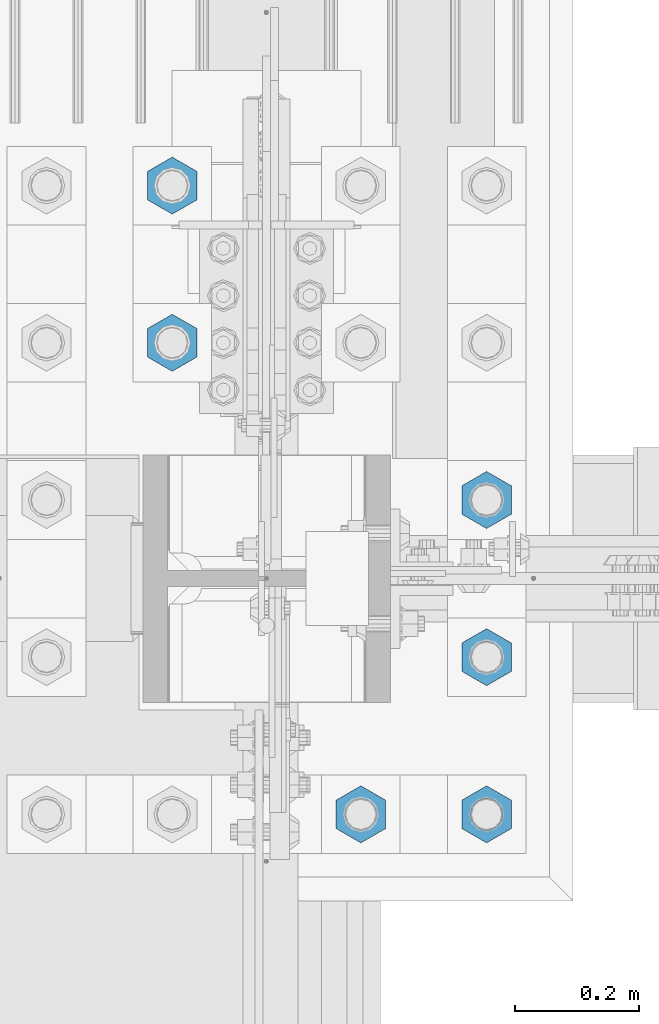
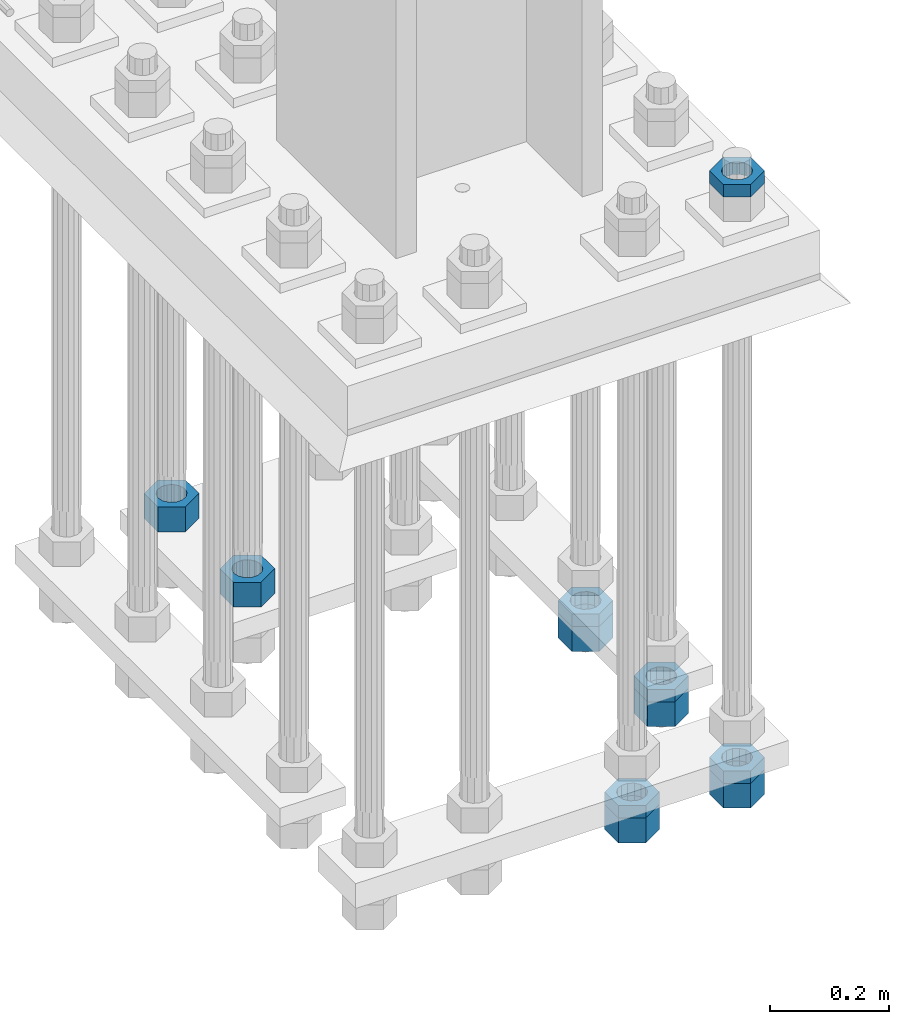
# One storey, part 2196 of 3843: 11 beams, 1 element without a shape of its own.
"""IFC2X3 building model written with IfcOpenShell, lengths in millimetres."""

import ifcopenshell
import ifcopenshell.guid

model = None  # the IFC model being written
_history = None  # IfcOwnerHistory: only IFC2X3 demands one
_inside = {}  # id of a spatial element -> (the spatial element, [elements in it])
_under = {}  # id of a project, library or spatial element -> (it, [spatial elements below it])
_declared = {}  # id of a project -> (the project, [libraries it declares])
_typed = {}  # id of a type object -> (the type object, [elements of that type])
_made_of = {}  # id of a material, layer set ... -> (it, [elements and type objects made of it])


def new_model(schema):
    """Start an empty IFC model of exactly this schema.

    Asked for "IFC4X3", IfcOpenShell would pick the latest addendum, in which some entities
    have other attributes; the version numbers below select the first issue.
    IFC2X3 requires an IfcOwnerHistory on every rooted entity: one is made here for all.
    """
    global model, _history
    if schema == "IFC4X3":
        model = ifcopenshell.file(schema_version=(4, 3, 0, 0))
    else:
        model = ifcopenshell.file(schema=schema)
    _inside.clear()
    _under.clear()
    _declared.clear()
    _typed.clear()
    _made_of.clear()
    _history = None
    if model.schema == "IFC2X3":
        org = make("IfcOrganization", Name="unknown")
        user = make(
            "IfcPersonAndOrganization",
            ThePerson=make("IfcPerson", FamilyName="unknown"),
            TheOrganization=org,
        )
        app = make(
            "IfcApplication",
            ApplicationDeveloper=org,
            Version="unknown",
            ApplicationFullName="unknown",
            ApplicationIdentifier="unknown",
        )
        _history = make(
            "IfcOwnerHistory",
            OwningUser=user,
            OwningApplication=app,
            ChangeAction="ADDED",
            CreationDate=0,
        )
    return model


def make(cls, **values):
    """One entity of the class cls with the attributes given. An attribute that is None is left unset."""
    return model.create_entity(
        cls, **{name: value for name, value in values.items() if value is not None}
    )


def rooted(cls, **values):
    """An entity with a GlobalId (a new one), such as an element, a storey or a relation."""
    return make(cls, GlobalId=ifcopenshell.guid.new(), OwnerHistory=_history, **values)


def si_unit(unit_type, name, prefix=None):
    """IfcSIUnit, for example si_unit("LENGTHUNIT", "METRE", prefix="MILLI")."""
    return make("IfcSIUnit", UnitType=unit_type, Prefix=prefix, Name=name)


def assignment(units):
    """IfcUnitAssignment: the units of a project."""
    return None if units is None else make("IfcUnitAssignment", Units=units)


def point(xyz):
    """IfcCartesianPoint."""
    return None if xyz is None else make("IfcCartesianPoint", Coordinates=xyz)


def direction(xyz):
    """IfcDirection."""
    return None if xyz is None else make("IfcDirection", DirectionRatios=xyz)


def frame(location, z_axis=None, x_axis=None):
    """IfcAxis2Placement3D, a coordinate frame: its origin and axes. An axis left out is left unset."""
    return make(
        "IfcAxis2Placement3D",
        Location=point(location),
        Axis=direction(z_axis),
        RefDirection=direction(x_axis),
    )


def origin_with_axes():
    """The frame at (0, 0, 0) with the z axis (0, 0, 1) and the x axis (1, 0, 0) written out."""
    return frame((0.0, 0.0, 0.0), z_axis=(0.0, 0.0, 1.0), x_axis=(1.0, 0.0, 0.0))


def place(relative_to, where):
    """IfcLocalPlacement: puts the frame where relative to a parent placement (None: the world)."""
    return make(
        "IfcLocalPlacement", PlacementRelTo=relative_to, RelativePlacement=where
    )


def context(
    kind, dimensions, precision=None, world=None, true_north=None, identifier=None
):
    """IfcGeometricRepresentationContext, for example the 3D "Model" context."""
    return make(
        "IfcGeometricRepresentationContext",
        ContextIdentifier=identifier,
        ContextType=kind,
        CoordinateSpaceDimension=dimensions,
        Precision=precision,
        WorldCoordinateSystem=world,
        TrueNorth=true_north,
    )


def subcontext(parent, identifier, kind, view, scale=None):
    """IfcGeometricRepresentationSubContext, for example "Body" below "Model"."""
    return make(
        "IfcGeometricRepresentationSubContext",
        ContextIdentifier=identifier,
        ContextType=kind,
        ParentContext=parent,
        TargetScale=scale,
        TargetView=view,
    )


def project(units=None, contexts=None):
    """IfcProject with its units and contexts."""
    return rooted(
        "IfcProject",
        Name="project",
        RepresentationContexts=contexts,
        UnitsInContext=assignment(units),
    )


def spatial(cls, under=None, at=None, **own):
    """A site, building, storey or space (cls), placed at a placement, below another one or the project."""
    s = rooted(cls, ObjectPlacement=at, **own)
    if under is not None:
        _under.setdefault(under.id(), (under, []))[1].append(s)
    return s


def faces_of(points, faces, orient=None, outer=None):
    """IfcFace entities. A face is a list of loops; a loop is a list of indices into points, from 0.

    orient and outer hold one flag for each loop. By default every Orientation is true, the
    first loop of a face is its IfcFaceOuterBound and the others are IfcFaceBound.
    """
    made = []
    for i, loops in enumerate(faces):
        bounds = []
        for j, loop in enumerate(loops):
            is_outer = j == 0 if outer is None else outer[i][j]
            bounds.append(
                make(
                    "IfcFaceOuterBound" if is_outer else "IfcFaceBound",
                    Bound=make("IfcPolyLoop", Polygon=[points[k] for k in loop]),
                    Orientation=True if orient is None else orient[i][j],
                )
            )
        made.append(make("IfcFace", Bounds=bounds))
    return made


def faceted_brep(points, faces, orient=None, outer=None, voids=None):
    """IfcFacetedBrep: a solid bounded by flat faces; with voids (closed shells), ...WithVoids."""
    shared = [point(p) for p in points]
    hull = make("IfcClosedShell", CfsFaces=faces_of(shared, faces, orient, outer))
    if voids is None:
        return make("IfcFacetedBrep", Outer=hull)
    return make(
        "IfcFacetedBrepWithVoids",
        Outer=hull,
        Voids=[
            make(cls, CfsFaces=faces_of(shared, fs, o, b)) for cls, fs, o, b in voids
        ],
    )


def shape(context_of_items, identifier, shape_type, items):
    """IfcShapeRepresentation: the items that make up one representation, for example the "Body"."""
    return make(
        "IfcShapeRepresentation",
        ContextOfItems=context_of_items,
        RepresentationIdentifier=identifier,
        RepresentationType=shape_type,
        Items=items,
    )


def material(Name=None, Category=None):
    """IfcMaterial."""
    return make("IfcMaterial", Name=Name, Category=Category)


def made_of(thing, what):
    """Note that an element or type object is made of a material, layer set ...; save() writes the relation."""
    if what is not None:
        _made_of.setdefault(what.id(), (what, []))[1].append(thing)
    return thing


def type_object(cls, material=None, **own):
    """A type object (cls), such as IfcWallType, which elements share."""
    return made_of(rooted(cls, **own), material)


def element(
    cls,
    number,
    at=None,
    inside=None,
    cuts=None,
    type_object=None,
    material=None,
    context=None,
    identifier="Body",
    shape_type=None,
    held_by="IfcProductDefinitionShape",
    body=None,
    shapes=None,
    **own,
):
    """One element of the class cls, such as IfcWall. Its Tag is "e" and its number.

    at: its placement. inside: the storey or other place that contains it. cuts: it is an
    opening in that element (IfcRelVoidsElement). A single representation is given by context,
    identifier, shape_type and body (its items); several are given by shapes. held_by: the class
    of the entity that holds the representations. save() writes the other relations.
    """
    e = rooted(cls, Tag="e%d" % number, ObjectPlacement=at, **own)
    if body is not None:
        shapes = [shape(context, identifier, shape_type, body)]
    if shapes is not None:
        e.Representation = make(held_by, Representations=shapes)
    if inside is not None:
        _inside.setdefault(inside.id(), (inside, []))[1].append(e)
    if cuts is not None:
        rooted(
            "IfcRelVoidsElement", RelatingBuildingElement=cuts, RelatedOpeningElement=e
        )
    if type_object is not None:
        _typed.setdefault(type_object.id(), (type_object, []))[1].append(e)
    return made_of(e, material)


def aggregate(whole, parts):
    """IfcRelAggregates: a whole, such as a stair, and the parts it consists of."""
    return rooted("IfcRelAggregates", RelatingObject=whole, RelatedObjects=parts)


def save(model, path):
    """Write the relations noted so far, then the file.

    IfcRelAggregates (storeys below a building ...), IfcRelContainedInSpatialStructure (elements
    in a storey), IfcRelDefinesByType, IfcRelAssociatesMaterial and IfcRelDeclares: one each for
    every whole, place, type object, material and project.
    """
    for whole, parts in _under.values():
        aggregate(whole, parts)
    for where, things in _inside.values():
        rooted(
            "IfcRelContainedInSpatialStructure",
            RelatedElements=things,
            RelatingStructure=where,
        )
    for kind, things in _typed.values():
        rooted("IfcRelDefinesByType", RelatedObjects=things, RelatingType=kind)
    for what, things in _made_of.values():
        rooted("IfcRelAssociatesMaterial", RelatedObjects=things, RelatingMaterial=what)
    for by, libraries in _declared.values():
        rooted("IfcRelDeclares", RelatingContext=by, RelatedDefinitions=libraries)
    model.write(path)


model = new_model("IFC2X3")

# Units and contexts
model_context = context("Model", 3, precision=1e-05, world=origin_with_axes())
body_context = subcontext(model_context, "Body", "Model", "MODEL_VIEW")
ifc_project = project(units=[si_unit("LENGTHUNIT", "METRE", prefix="MILLI"), si_unit("AREAUNIT", "SQUARE_METRE"), si_unit("VOLUMEUNIT", "CUBIC_METRE"), si_unit("MASSUNIT", "GRAM", prefix="KILO"), si_unit("TIMEUNIT", "SECOND"), si_unit("PLANEANGLEUNIT", "RADIAN"), si_unit("SOLIDANGLEUNIT", "STERADIAN"), si_unit("THERMODYNAMICTEMPERATUREUNIT", "DEGREE_CELSIUS"), si_unit("LUMINOUSINTENSITYUNIT", "LUMEN")], contexts=[model_context])

# Site, building, storey
site_placement = place(None, origin_with_axes())
site = spatial("IfcSite", under=ifc_project, at=site_placement, CompositionType="ELEMENT")
building_placement = place(site_placement, origin_with_axes())
building = spatial("IfcBuilding", under=site, at=building_placement, Name="Undefined", CompositionType="ELEMENT")
storey_placement = place(building_placement, origin_with_axes())
storey = spatial("IfcBuildingStorey", under=building, at=storey_placement, Name="Undefined", CompositionType="ELEMENT", Elevation=0.0)

# Assembly, beams
assembly_placement = place(storey_placement, origin_with_axes())
assembly = element("IfcElementAssembly", 1, at=assembly_placement, inside=storey, Name="TEMPLATE", AssemblyPlace="NOTDEFINED", PredefinedType="RIGID_FRAME")
ifc_material = material(Name="STEEL/A572-50")
beam_type_1 = type_object("IfcBeamType", Name="2_HALF_NUT", PredefinedType="NOTDEFINED")
beam_1_placement = place(assembly_placement, frame((36931.6, 50177.7, 30257.75), z_axis=(1.0, 0.0, 0.0), x_axis=(0.0, 0.0, -1.0)))
beam_1 = element("IfcBeam", 2, at=beam_1_placement, type_object=beam_type_1, material=ifc_material, Name="NUT", ObjectType="2_HALF_NUT", context=body_context, shape_type="Brep", body=[
    faceted_brep([(0.0, -46.0369987487793, 0.0), (0.0, -23.0184993743896, -39.869213104248), (25.4000000000015, -23.0184993743896, -39.869213104248), (25.4000000000015, -46.0369987487793, 0.0), (0.0, 23.0184993743896, -39.869213104248), (25.4000000000015, 23.0184993743896, -39.869213104248), (0.0, 46.0369987487793, 0.0), (25.4000000000015, 46.0369987487793, 0.0), (0.0, 23.0184993743896, 39.869213104248), (25.4000000000015, 23.0184993743896, 39.869213104248), (0.0, -23.0184993743896, 39.869213104248), (25.4000000000015, -23.0184993743896, 39.869213104248), (0.0, 0.0, 26.1940002441406), (0.0, 11.3650617044477, 23.5999013092805), (25.4000000000015, 11.3650617044477, 23.5999013092805), (25.4000000000015, 0.0, 26.1940002441406), (0.0, 20.4791109456419, 16.3316083006721), (25.4000000000015, 20.4791109456419, 16.3316083006721), (0.0, 25.5370200498292, 5.82867859874386), (25.4000000000015, 25.5370200498292, 5.82867859874386), (0.0, 25.5370200498292, -5.82867859874386), (25.4000000000015, 25.5370200498292, -5.82867859874386), (0.0, 20.4791109456419, -16.3316083006721), (25.4000000000015, 20.4791109456419, -16.3316083006721), (0.0, 11.3650617044477, -23.5999013092805), (25.4000000000015, 11.3650617044477, -23.5999013092805), (0.0, 0.0, -26.1940002441406), (25.4000000000015, 0.0, -26.1940002441406), (0.0, -11.3650617044477, -23.5999013092805), (25.4000000000015, -11.3650617044477, -23.5999013092805), (0.0, -20.4791109456419, -16.3316083006721), (25.4000000000015, -20.4791109456419, -16.3316083006721), (0.0, -25.5370200498292, -5.82867859874386), (25.4000000000015, -25.5370200498292, -5.82867859874386), (0.0, -25.5370200498292, 5.82867859874386), (25.4000000000015, -25.5370200498292, 5.82867859874386), (0.0, -20.4791109456419, 16.3316083006721), (25.4000000000015, -20.4791109456419, 16.3316083006721), (0.0, -11.3650617044477, 23.5999013092805), (25.4000000000015, -11.3650617044477, 23.5999013092805)], [[[0, 1, 2, 3]], [[1, 4, 5, 2]], [[4, 6, 7, 5]], [[6, 8, 9, 7]], [[8, 10, 11, 9]], [[10, 0, 3, 11]], [[12, 13, 14, 15]], [[13, 16, 17, 14]], [[16, 18, 19, 17]], [[18, 20, 21, 19]], [[20, 22, 23, 21]], [[22, 24, 25, 23]], [[24, 26, 27, 25]], [[26, 28, 29, 27]], [[28, 30, 31, 29]], [[30, 32, 33, 31]], [[32, 34, 35, 33]], [[34, 36, 37, 35]], [[36, 38, 39, 37]], [[38, 12, 15, 39]], [[5, 7, 9, 11, 3, 2], [17, 19, 21, 23, 25, 27, 29, 31, 33, 35, 37, 39, 15, 14]], [[10, 8, 6, 4, 1, 0], [38, 36, 34, 32, 30, 28, 26, 24, 22, 20, 18, 16, 13, 12]]]),
])
beam_2_placement = place(assembly_placement, frame((36931.6, 50177.7, 29057.6), z_axis=(1.0, 0.0, 0.0), x_axis=(0.0, 0.0, -1.0)))
beam_2 = element("IfcBeam", 3, at=beam_2_placement, type_object=beam_type_1, material=ifc_material, Name="NUT", ObjectType="2_HALF_NUT", context=body_context, shape_type="Brep", body=[
    faceted_brep([(0.0, -46.0369987487793, 0.0), (0.0, -23.0184993743896, -39.869213104248), (25.4000000000015, -23.0184993743896, -39.869213104248), (25.4000000000015, -46.0369987487793, 0.0), (0.0, 23.0184993743896, -39.869213104248), (25.4000000000015, 23.0184993743896, -39.869213104248), (0.0, 46.0369987487793, 0.0), (25.4000000000015, 46.0369987487793, 0.0), (0.0, 23.0184993743896, 39.869213104248), (25.4000000000015, 23.0184993743896, 39.869213104248), (0.0, -23.0184993743896, 39.869213104248), (25.4000000000015, -23.0184993743896, 39.869213104248), (0.0, 0.0, 26.1940002441406), (0.0, 11.3650617044477, 23.5999013092805), (25.4000000000015, 11.3650617044477, 23.5999013092805), (25.4000000000015, 0.0, 26.1940002441406), (0.0, 20.4791109456419, 16.3316083006721), (25.4000000000015, 20.4791109456419, 16.3316083006721), (0.0, 25.5370200498292, 5.82867859874386), (25.4000000000015, 25.5370200498292, 5.82867859874386), (0.0, 25.5370200498292, -5.82867859874386), (25.4000000000015, 25.5370200498292, -5.82867859874386), (0.0, 20.4791109456419, -16.3316083006721), (25.4000000000015, 20.4791109456419, -16.3316083006721), (0.0, 11.3650617044477, -23.5999013092805), (25.4000000000015, 11.3650617044477, -23.5999013092805), (0.0, 0.0, -26.1940002441406), (25.4000000000015, 0.0, -26.1940002441406), (0.0, -11.3650617044477, -23.5999013092805), (25.4000000000015, -11.3650617044477, -23.5999013092805), (0.0, -20.4791109456419, -16.3316083006721), (25.4000000000015, -20.4791109456419, -16.3316083006721), (0.0, -25.5370200498292, -5.82867859874386), (25.4000000000015, -25.5370200498292, -5.82867859874386), (0.0, -25.5370200498292, 5.82867859874386), (25.4000000000015, -25.5370200498292, 5.82867859874386), (0.0, -20.4791109456419, 16.3316083006721), (25.4000000000015, -20.4791109456419, 16.3316083006721), (0.0, -11.3650617044477, 23.5999013092805), (25.4000000000015, -11.3650617044477, 23.5999013092805)], [[[0, 1, 2, 3]], [[1, 4, 5, 2]], [[4, 6, 7, 5]], [[6, 8, 9, 7]], [[8, 10, 11, 9]], [[10, 0, 3, 11]], [[12, 13, 14, 15]], [[13, 16, 17, 14]], [[16, 18, 19, 17]], [[18, 20, 21, 19]], [[20, 22, 23, 21]], [[22, 24, 25, 23]], [[24, 26, 27, 25]], [[26, 28, 29, 27]], [[28, 30, 31, 29]], [[30, 32, 33, 31]], [[32, 34, 35, 33]], [[34, 36, 37, 35]], [[36, 38, 39, 37]], [[38, 12, 15, 39]], [[5, 7, 9, 11, 3, 2], [17, 19, 21, 23, 25, 27, 29, 31, 33, 35, 37, 39, 15, 14]], [[10, 8, 6, 4, 1, 0], [38, 36, 34, 32, 30, 28, 26, 24, 22, 20, 18, 16, 13, 12]]]),
])
beam_3_placement = place(assembly_placement, frame((36728.4, 50177.7, 29057.6), z_axis=(1.0, 0.0, 0.0), x_axis=(0.0, 0.0, -1.0)))
beam_3 = element("IfcBeam", 4, at=beam_3_placement, type_object=beam_type_1, material=ifc_material, Name="NUT", ObjectType="2_HALF_NUT", context=body_context, shape_type="Brep", body=[
    faceted_brep([(0.0, -46.0369987487793, 0.0), (0.0, -23.0184993743896, -39.869213104248), (25.4000000000015, -23.0184993743896, -39.869213104248), (25.4000000000015, -46.0369987487793, 0.0), (0.0, 23.0184993743896, -39.869213104248), (25.4000000000015, 23.0184993743896, -39.869213104248), (0.0, 46.0369987487793, 0.0), (25.4000000000015, 46.0369987487793, 0.0), (0.0, 23.0184993743896, 39.869213104248), (25.4000000000015, 23.0184993743896, 39.869213104248), (0.0, -23.0184993743896, 39.869213104248), (25.4000000000015, -23.0184993743896, 39.869213104248), (0.0, 0.0, 26.1940002441406), (0.0, 11.3650617044477, 23.5999013092805), (25.4000000000015, 11.3650617044477, 23.5999013092805), (25.4000000000015, 0.0, 26.1940002441406), (0.0, 20.4791109456419, 16.3316083006721), (25.4000000000015, 20.4791109456419, 16.3316083006721), (0.0, 25.5370200498292, 5.82867859874386), (25.4000000000015, 25.5370200498292, 5.82867859874386), (0.0, 25.5370200498292, -5.82867859874386), (25.4000000000015, 25.5370200498292, -5.82867859874386), (0.0, 20.4791109456419, -16.3316083006721), (25.4000000000015, 20.4791109456419, -16.3316083006721), (0.0, 11.3650617044477, -23.5999013092805), (25.4000000000015, 11.3650617044477, -23.5999013092805), (0.0, 0.0, -26.1940002441406), (25.4000000000015, 0.0, -26.1940002441406), (0.0, -11.3650617044477, -23.5999013092805), (25.4000000000015, -11.3650617044477, -23.5999013092805), (0.0, -20.4791109456419, -16.3316083006721), (25.4000000000015, -20.4791109456419, -16.3316083006721), (0.0, -25.5370200498292, -5.82867859874386), (25.4000000000015, -25.5370200498292, -5.82867859874386), (0.0, -25.5370200498292, 5.82867859874386), (25.4000000000015, -25.5370200498292, 5.82867859874386), (0.0, -20.4791109456419, 16.3316083006721), (25.4000000000015, -20.4791109456419, 16.3316083006721), (0.0, -11.3650617044477, 23.5999013092805), (25.4000000000015, -11.3650617044477, 23.5999013092805)], [[[0, 1, 2, 3]], [[1, 4, 5, 2]], [[4, 6, 7, 5]], [[6, 8, 9, 7]], [[8, 10, 11, 9]], [[10, 0, 3, 11]], [[12, 13, 14, 15]], [[13, 16, 17, 14]], [[16, 18, 19, 17]], [[18, 20, 21, 19]], [[20, 22, 23, 21]], [[22, 24, 25, 23]], [[24, 26, 27, 25]], [[26, 28, 29, 27]], [[28, 30, 31, 29]], [[30, 32, 33, 31]], [[32, 34, 35, 33]], [[34, 36, 37, 35]], [[36, 38, 39, 37]], [[38, 12, 15, 39]], [[5, 7, 9, 11, 3, 2], [17, 19, 21, 23, 25, 27, 29, 31, 33, 35, 37, 39, 15, 14]], [[10, 8, 6, 4, 1, 0], [38, 36, 34, 32, 30, 28, 26, 24, 22, 20, 18, 16, 13, 12]]]),
])
beam_4_placement = place(assembly_placement, frame((36931.6, 50431.7, 29070.3), z_axis=(1.0, 0.0, 0.0), x_axis=(0.0, 0.0, -1.0)))
beam_4 = element("IfcBeam", 5, at=beam_4_placement, type_object=beam_type_1, material=ifc_material, Name="NUT", ObjectType="2_HALF_NUT", context=body_context, shape_type="Brep", body=[
    faceted_brep([(0.0, -46.0369987487793, 0.0), (0.0, -23.0184993743896, -39.869213104248), (25.4000000000015, -23.0184993743896, -39.869213104248), (25.4000000000015, -46.0369987487793, 0.0), (0.0, 23.0184993743896, -39.869213104248), (25.4000000000015, 23.0184993743896, -39.869213104248), (0.0, 46.0369987487793, 0.0), (25.4000000000015, 46.0369987487793, 0.0), (0.0, 23.0184993743896, 39.869213104248), (25.4000000000015, 23.0184993743896, 39.869213104248), (0.0, -23.0184993743896, 39.869213104248), (25.4000000000015, -23.0184993743896, 39.869213104248), (0.0, 0.0, 26.1940002441406), (0.0, 11.3650617044477, 23.5999013092805), (25.4000000000015, 11.3650617044477, 23.5999013092805), (25.4000000000015, 0.0, 26.1940002441406), (0.0, 20.4791109456419, 16.3316083006721), (25.4000000000015, 20.4791109456419, 16.3316083006721), (0.0, 25.5370200498292, 5.82867859874386), (25.4000000000015, 25.5370200498292, 5.82867859874386), (0.0, 25.5370200498292, -5.82867859874386), (25.4000000000015, 25.5370200498292, -5.82867859874386), (0.0, 20.4791109456419, -16.3316083006721), (25.4000000000015, 20.4791109456419, -16.3316083006721), (0.0, 11.3650617044477, -23.5999013092805), (25.4000000000015, 11.3650617044477, -23.5999013092805), (0.0, 0.0, -26.1940002441406), (25.4000000000015, 0.0, -26.1940002441406), (0.0, -11.3650617044477, -23.5999013092805), (25.4000000000015, -11.3650617044477, -23.5999013092805), (0.0, -20.4791109456419, -16.3316083006721), (25.4000000000015, -20.4791109456419, -16.3316083006721), (0.0, -25.5370200498292, -5.82867859874386), (25.4000000000015, -25.5370200498292, -5.82867859874386), (0.0, -25.5370200498292, 5.82867859874386), (25.4000000000015, -25.5370200498292, 5.82867859874386), (0.0, -20.4791109456419, 16.3316083006721), (25.4000000000015, -20.4791109456419, 16.3316083006721), (0.0, -11.3650617044477, 23.5999013092805), (25.4000000000015, -11.3650617044477, 23.5999013092805)], [[[0, 1, 2, 3]], [[1, 4, 5, 2]], [[4, 6, 7, 5]], [[6, 8, 9, 7]], [[8, 10, 11, 9]], [[10, 0, 3, 11]], [[12, 13, 14, 15]], [[13, 16, 17, 14]], [[16, 18, 19, 17]], [[18, 20, 21, 19]], [[20, 22, 23, 21]], [[22, 24, 25, 23]], [[24, 26, 27, 25]], [[26, 28, 29, 27]], [[28, 30, 31, 29]], [[30, 32, 33, 31]], [[32, 34, 35, 33]], [[34, 36, 37, 35]], [[36, 38, 39, 37]], [[38, 12, 15, 39]], [[5, 7, 9, 11, 3, 2], [17, 19, 21, 23, 25, 27, 29, 31, 33, 35, 37, 39, 15, 14]], [[10, 8, 6, 4, 1, 0], [38, 36, 34, 32, 30, 28, 26, 24, 22, 20, 18, 16, 13, 12]]]),
])
beam_5_placement = place(assembly_placement, frame((36931.6, 50685.7, 29070.3), z_axis=(1.0, 0.0, 0.0), x_axis=(0.0, 0.0, -1.0)))
beam_5 = element("IfcBeam", 6, at=beam_5_placement, type_object=beam_type_1, material=ifc_material, Name="NUT", ObjectType="2_HALF_NUT", context=body_context, shape_type="Brep", body=[
    faceted_brep([(0.0, -46.0369987487793, 0.0), (0.0, -23.0184993743896, -39.869213104248), (25.4000000000015, -23.0184993743896, -39.869213104248), (25.4000000000015, -46.0369987487793, 0.0), (0.0, 23.0184993743896, -39.869213104248), (25.4000000000015, 23.0184993743896, -39.869213104248), (0.0, 46.0369987487793, 0.0), (25.4000000000015, 46.0369987487793, 0.0), (0.0, 23.0184993743896, 39.869213104248), (25.4000000000015, 23.0184993743896, 39.869213104248), (0.0, -23.0184993743896, 39.869213104248), (25.4000000000015, -23.0184993743896, 39.869213104248), (0.0, 0.0, 26.1940002441406), (0.0, 11.3650617044477, 23.5999013092805), (25.4000000000015, 11.3650617044477, 23.5999013092805), (25.4000000000015, 0.0, 26.1940002441406), (0.0, 20.4791109456419, 16.3316083006721), (25.4000000000015, 20.4791109456419, 16.3316083006721), (0.0, 25.5370200498292, 5.82867859874386), (25.4000000000015, 25.5370200498292, 5.82867859874386), (0.0, 25.5370200498292, -5.82867859874386), (25.4000000000015, 25.5370200498292, -5.82867859874386), (0.0, 20.4791109456419, -16.3316083006721), (25.4000000000015, 20.4791109456419, -16.3316083006721), (0.0, 11.3650617044477, -23.5999013092805), (25.4000000000015, 11.3650617044477, -23.5999013092805), (0.0, 0.0, -26.1940002441406), (25.4000000000015, 0.0, -26.1940002441406), (0.0, -11.3650617044477, -23.5999013092805), (25.4000000000015, -11.3650617044477, -23.5999013092805), (0.0, -20.4791109456419, -16.3316083006721), (25.4000000000015, -20.4791109456419, -16.3316083006721), (0.0, -25.5370200498292, -5.82867859874386), (25.4000000000015, -25.5370200498292, -5.82867859874386), (0.0, -25.5370200498292, 5.82867859874386), (25.4000000000015, -25.5370200498292, 5.82867859874386), (0.0, -20.4791109456419, 16.3316083006721), (25.4000000000015, -20.4791109456419, 16.3316083006721), (0.0, -11.3650617044477, 23.5999013092805), (25.4000000000015, -11.3650617044477, 23.5999013092805)], [[[0, 1, 2, 3]], [[1, 4, 5, 2]], [[4, 6, 7, 5]], [[6, 8, 9, 7]], [[8, 10, 11, 9]], [[10, 0, 3, 11]], [[12, 13, 14, 15]], [[13, 16, 17, 14]], [[16, 18, 19, 17]], [[18, 20, 21, 19]], [[20, 22, 23, 21]], [[22, 24, 25, 23]], [[24, 26, 27, 25]], [[26, 28, 29, 27]], [[28, 30, 31, 29]], [[30, 32, 33, 31]], [[32, 34, 35, 33]], [[34, 36, 37, 35]], [[36, 38, 39, 37]], [[38, 12, 15, 39]], [[5, 7, 9, 11, 3, 2], [17, 19, 21, 23, 25, 27, 29, 31, 33, 35, 37, 39, 15, 14]], [[10, 8, 6, 4, 1, 0], [38, 36, 34, 32, 30, 28, 26, 24, 22, 20, 18, 16, 13, 12]]]),
])
beam_type_2 = type_object("IfcBeamType", Name="2_HEAVY_HEX_NUT", PredefinedType="NOTDEFINED")
beam_6_placement = place(assembly_placement, frame((36423.6, 51193.7, 29159.2), z_axis=(-1.0, 0.0, 0.0), x_axis=(0.0, 0.0, -1.0)))
beam_6 = element("IfcBeam", 7, at=beam_6_placement, type_object=beam_type_2, material=ifc_material, Name="NUT", ObjectType="2_HEAVY_HEX_NUT", context=body_context, shape_type="Brep", body=[
    faceted_brep([(0.0, -46.0369987487793, 0.0), (0.0, -23.0184993743896, -39.869213104248), (50.7999999999993, -23.0184993743896, -39.869213104248), (50.7999999999993, -46.0369987487793, 0.0), (0.0, 23.0184993743896, -39.869213104248), (50.7999999999993, 23.0184993743896, -39.869213104248), (0.0, 46.0369987487793, 0.0), (50.7999999999993, 46.0369987487793, 0.0), (0.0, 23.0184993743896, 39.869213104248), (50.7999999999993, 23.0184993743896, 39.869213104248), (0.0, -23.0184993743896, 39.869213104248), (50.7999999999993, -23.0184993743896, 39.869213104248), (0.0, 0.0, 26.1940002441406), (0.0, 11.3650617044477, 23.5999013092805), (50.7999999999993, 11.3650617044477, 23.5999013092805), (50.7999999999993, 0.0, 26.1940002441406), (0.0, 20.4791109456419, 16.3316083006721), (50.7999999999993, 20.4791109456419, 16.3316083006721), (0.0, 25.5370200498292, 5.82867859874386), (50.7999999999993, 25.5370200498292, 5.82867859874386), (0.0, 25.5370200498292, -5.82867859874386), (50.7999999999993, 25.5370200498292, -5.82867859874386), (0.0, 20.4791109456419, -16.3316083006721), (50.7999999999993, 20.4791109456419, -16.3316083006721), (0.0, 11.3650617044477, -23.5999013092805), (50.7999999999993, 11.3650617044477, -23.5999013092805), (0.0, 0.0, -26.1940002441406), (50.7999999999993, 0.0, -26.1940002441406), (0.0, -11.3650617044477, -23.5999013092805), (50.7999999999993, -11.3650617044477, -23.5999013092805), (0.0, -20.4791109456419, -16.3316083006721), (50.7999999999993, -20.4791109456419, -16.3316083006721), (0.0, -25.5370200498292, -5.82867859874386), (50.7999999999993, -25.5370200498292, -5.82867859874386), (0.0, -25.5370200498292, 5.82867859874386), (50.7999999999993, -25.5370200498292, 5.82867859874386), (0.0, -20.4791109456419, 16.3316083006721), (50.7999999999993, -20.4791109456419, 16.3316083006721), (0.0, -11.3650617044477, 23.5999013092805), (50.7999999999993, -11.3650617044477, 23.5999013092805)], [[[0, 1, 2, 3]], [[1, 4, 5, 2]], [[4, 6, 7, 5]], [[6, 8, 9, 7]], [[8, 10, 11, 9]], [[10, 0, 3, 11]], [[12, 13, 14, 15]], [[13, 16, 17, 14]], [[16, 18, 19, 17]], [[18, 20, 21, 19]], [[20, 22, 23, 21]], [[22, 24, 25, 23]], [[24, 26, 27, 25]], [[26, 28, 29, 27]], [[28, 30, 31, 29]], [[30, 32, 33, 31]], [[32, 34, 35, 33]], [[34, 36, 37, 35]], [[36, 38, 39, 37]], [[38, 12, 15, 39]], [[5, 7, 9, 11, 3, 2], [17, 19, 21, 23, 25, 27, 29, 31, 33, 35, 37, 39, 15, 14]], [[10, 8, 6, 4, 1, 0], [38, 36, 34, 32, 30, 28, 26, 24, 22, 20, 18, 16, 13, 12]]]),
])
beam_7_placement = place(assembly_placement, frame((36423.6, 50939.7, 29159.2), z_axis=(-1.0, 0.0, 0.0), x_axis=(0.0, 0.0, -1.0)))
beam_7 = element("IfcBeam", 8, at=beam_7_placement, type_object=beam_type_2, material=ifc_material, Name="NUT", ObjectType="2_HEAVY_HEX_NUT", context=body_context, shape_type="Brep", body=[
    faceted_brep([(0.0, -46.0369987487793, 0.0), (0.0, -23.0184993743896, -39.869213104248), (50.7999999999993, -23.0184993743896, -39.869213104248), (50.7999999999993, -46.0369987487793, 0.0), (0.0, 23.0184993743896, -39.869213104248), (50.7999999999993, 23.0184993743896, -39.869213104248), (0.0, 46.0369987487793, 0.0), (50.7999999999993, 46.0369987487793, 0.0), (0.0, 23.0184993743896, 39.869213104248), (50.7999999999993, 23.0184993743896, 39.869213104248), (0.0, -23.0184993743896, 39.869213104248), (50.7999999999993, -23.0184993743896, 39.869213104248), (0.0, 0.0, 26.1940002441406), (0.0, 11.3650617044477, 23.5999013092805), (50.7999999999993, 11.3650617044477, 23.5999013092805), (50.7999999999993, 0.0, 26.1940002441406), (0.0, 20.4791109456419, 16.3316083006721), (50.7999999999993, 20.4791109456419, 16.3316083006721), (0.0, 25.5370200498292, 5.82867859874386), (50.7999999999993, 25.5370200498292, 5.82867859874386), (0.0, 25.5370200498292, -5.82867859874386), (50.7999999999993, 25.5370200498292, -5.82867859874386), (0.0, 20.4791109456419, -16.3316083006721), (50.7999999999993, 20.4791109456419, -16.3316083006721), (0.0, 11.3650617044477, -23.5999013092805), (50.7999999999993, 11.3650617044477, -23.5999013092805), (0.0, 0.0, -26.1940002441406), (50.7999999999993, 0.0, -26.1940002441406), (0.0, -11.3650617044477, -23.5999013092805), (50.7999999999993, -11.3650617044477, -23.5999013092805), (0.0, -20.4791109456419, -16.3316083006721), (50.7999999999993, -20.4791109456419, -16.3316083006721), (0.0, -25.5370200498292, -5.82867859874386), (50.7999999999993, -25.5370200498292, -5.82867859874386), (0.0, -25.5370200498292, 5.82867859874386), (50.7999999999993, -25.5370200498292, 5.82867859874386), (0.0, -20.4791109456419, 16.3316083006721), (50.7999999999993, -20.4791109456419, 16.3316083006721), (0.0, -11.3650617044477, 23.5999013092805), (50.7999999999993, -11.3650617044477, 23.5999013092805)], [[[0, 1, 2, 3]], [[1, 4, 5, 2]], [[4, 6, 7, 5]], [[6, 8, 9, 7]], [[8, 10, 11, 9]], [[10, 0, 3, 11]], [[12, 13, 14, 15]], [[13, 16, 17, 14]], [[16, 18, 19, 17]], [[18, 20, 21, 19]], [[20, 22, 23, 21]], [[22, 24, 25, 23]], [[24, 26, 27, 25]], [[26, 28, 29, 27]], [[28, 30, 31, 29]], [[30, 32, 33, 31]], [[32, 34, 35, 33]], [[34, 36, 37, 35]], [[36, 38, 39, 37]], [[38, 12, 15, 39]], [[5, 7, 9, 11, 3, 2], [17, 19, 21, 23, 25, 27, 29, 31, 33, 35, 37, 39, 15, 14]], [[10, 8, 6, 4, 1, 0], [38, 36, 34, 32, 30, 28, 26, 24, 22, 20, 18, 16, 13, 12]]]),
])
beam_8_placement = place(assembly_placement, frame((36931.6, 50177.7, 29032.2), z_axis=(1.0, 0.0, 0.0), x_axis=(0.0, 0.0, -1.0)))
beam_8 = element("IfcBeam", 9, at=beam_8_placement, type_object=beam_type_2, material=ifc_material, Name="NUT", ObjectType="2_HEAVY_HEX_NUT", context=body_context, shape_type="Brep", body=[
    faceted_brep([(0.0, -46.0369987487793, 0.0), (0.0, -23.0184993743896, -39.869213104248), (50.7999999999993, -23.0184993743896, -39.869213104248), (50.7999999999993, -46.0369987487793, 0.0), (0.0, 23.0184993743896, -39.869213104248), (50.7999999999993, 23.0184993743896, -39.869213104248), (0.0, 46.0369987487793, 0.0), (50.7999999999993, 46.0369987487793, 0.0), (0.0, 23.0184993743896, 39.869213104248), (50.7999999999993, 23.0184993743896, 39.869213104248), (0.0, -23.0184993743896, 39.869213104248), (50.7999999999993, -23.0184993743896, 39.869213104248), (0.0, 0.0, 26.1940002441406), (0.0, 11.3650617044477, 23.5999013092805), (50.7999999999993, 11.3650617044477, 23.5999013092805), (50.7999999999993, 0.0, 26.1940002441406), (0.0, 20.4791109456419, 16.3316083006721), (50.7999999999993, 20.4791109456419, 16.3316083006721), (0.0, 25.5370200498292, 5.82867859874386), (50.7999999999993, 25.5370200498292, 5.82867859874386), (0.0, 25.5370200498292, -5.82867859874386), (50.7999999999993, 25.5370200498292, -5.82867859874386), (0.0, 20.4791109456419, -16.3316083006721), (50.7999999999993, 20.4791109456419, -16.3316083006721), (0.0, 11.3650617044477, -23.5999013092805), (50.7999999999993, 11.3650617044477, -23.5999013092805), (0.0, 0.0, -26.1940002441406), (50.7999999999993, 0.0, -26.1940002441406), (0.0, -11.3650617044477, -23.5999013092805), (50.7999999999993, -11.3650617044477, -23.5999013092805), (0.0, -20.4791109456419, -16.3316083006721), (50.7999999999993, -20.4791109456419, -16.3316083006721), (0.0, -25.5370200498292, -5.82867859874386), (50.7999999999993, -25.5370200498292, -5.82867859874386), (0.0, -25.5370200498292, 5.82867859874386), (50.7999999999993, -25.5370200498292, 5.82867859874386), (0.0, -20.4791109456419, 16.3316083006721), (50.7999999999993, -20.4791109456419, 16.3316083006721), (0.0, -11.3650617044477, 23.5999013092805), (50.7999999999993, -11.3650617044477, 23.5999013092805)], [[[0, 1, 2, 3]], [[1, 4, 5, 2]], [[4, 6, 7, 5]], [[6, 8, 9, 7]], [[8, 10, 11, 9]], [[10, 0, 3, 11]], [[12, 13, 14, 15]], [[13, 16, 17, 14]], [[16, 18, 19, 17]], [[18, 20, 21, 19]], [[20, 22, 23, 21]], [[22, 24, 25, 23]], [[24, 26, 27, 25]], [[26, 28, 29, 27]], [[28, 30, 31, 29]], [[30, 32, 33, 31]], [[32, 34, 35, 33]], [[34, 36, 37, 35]], [[36, 38, 39, 37]], [[38, 12, 15, 39]], [[5, 7, 9, 11, 3, 2], [17, 19, 21, 23, 25, 27, 29, 31, 33, 35, 37, 39, 15, 14]], [[10, 8, 6, 4, 1, 0], [38, 36, 34, 32, 30, 28, 26, 24, 22, 20, 18, 16, 13, 12]]]),
])
beam_9_placement = place(assembly_placement, frame((36728.4, 50177.7, 29032.2), z_axis=(1.0, 0.0, 0.0), x_axis=(0.0, 0.0, -1.0)))
beam_9 = element("IfcBeam", 10, at=beam_9_placement, type_object=beam_type_2, material=ifc_material, Name="NUT", ObjectType="2_HEAVY_HEX_NUT", context=body_context, shape_type="Brep", body=[
    faceted_brep([(0.0, -46.0369987487793, 0.0), (0.0, -23.0184993743896, -39.869213104248), (50.7999999999993, -23.0184993743896, -39.869213104248), (50.7999999999993, -46.0369987487793, 0.0), (0.0, 23.0184993743896, -39.869213104248), (50.7999999999993, 23.0184993743896, -39.869213104248), (0.0, 46.0369987487793, 0.0), (50.7999999999993, 46.0369987487793, 0.0), (0.0, 23.0184993743896, 39.869213104248), (50.7999999999993, 23.0184993743896, 39.869213104248), (0.0, -23.0184993743896, 39.869213104248), (50.7999999999993, -23.0184993743896, 39.869213104248), (0.0, 0.0, 26.1940002441406), (0.0, 11.3650617044477, 23.5999013092805), (50.7999999999993, 11.3650617044477, 23.5999013092805), (50.7999999999993, 0.0, 26.1940002441406), (0.0, 20.4791109456419, 16.3316083006721), (50.7999999999993, 20.4791109456419, 16.3316083006721), (0.0, 25.5370200498292, 5.82867859874386), (50.7999999999993, 25.5370200498292, 5.82867859874386), (0.0, 25.5370200498292, -5.82867859874386), (50.7999999999993, 25.5370200498292, -5.82867859874386), (0.0, 20.4791109456419, -16.3316083006721), (50.7999999999993, 20.4791109456419, -16.3316083006721), (0.0, 11.3650617044477, -23.5999013092805), (50.7999999999993, 11.3650617044477, -23.5999013092805), (0.0, 0.0, -26.1940002441406), (50.7999999999993, 0.0, -26.1940002441406), (0.0, -11.3650617044477, -23.5999013092805), (50.7999999999993, -11.3650617044477, -23.5999013092805), (0.0, -20.4791109456419, -16.3316083006721), (50.7999999999993, -20.4791109456419, -16.3316083006721), (0.0, -25.5370200498292, -5.82867859874386), (50.7999999999993, -25.5370200498292, -5.82867859874386), (0.0, -25.5370200498292, 5.82867859874386), (50.7999999999993, -25.5370200498292, 5.82867859874386), (0.0, -20.4791109456419, 16.3316083006721), (50.7999999999993, -20.4791109456419, 16.3316083006721), (0.0, -11.3650617044477, 23.5999013092805), (50.7999999999993, -11.3650617044477, 23.5999013092805)], [[[0, 1, 2, 3]], [[1, 4, 5, 2]], [[4, 6, 7, 5]], [[6, 8, 9, 7]], [[8, 10, 11, 9]], [[10, 0, 3, 11]], [[12, 13, 14, 15]], [[13, 16, 17, 14]], [[16, 18, 19, 17]], [[18, 20, 21, 19]], [[20, 22, 23, 21]], [[22, 24, 25, 23]], [[24, 26, 27, 25]], [[26, 28, 29, 27]], [[28, 30, 31, 29]], [[30, 32, 33, 31]], [[32, 34, 35, 33]], [[34, 36, 37, 35]], [[36, 38, 39, 37]], [[38, 12, 15, 39]], [[5, 7, 9, 11, 3, 2], [17, 19, 21, 23, 25, 27, 29, 31, 33, 35, 37, 39, 15, 14]], [[10, 8, 6, 4, 1, 0], [38, 36, 34, 32, 30, 28, 26, 24, 22, 20, 18, 16, 13, 12]]]),
])
beam_10_placement = place(assembly_placement, frame((36931.6, 50431.7, 29044.9), z_axis=(1.0, 0.0, 0.0), x_axis=(0.0, 0.0, -1.0)))
beam_10 = element("IfcBeam", 11, at=beam_10_placement, type_object=beam_type_2, material=ifc_material, Name="NUT", ObjectType="2_HEAVY_HEX_NUT", context=body_context, shape_type="Brep", body=[
    faceted_brep([(0.0, -46.0369987487793, 0.0), (0.0, -23.0184993743896, -39.869213104248), (50.7999999999993, -23.0184993743896, -39.869213104248), (50.7999999999993, -46.0369987487793, 0.0), (0.0, 23.0184993743896, -39.869213104248), (50.7999999999993, 23.0184993743896, -39.869213104248), (0.0, 46.0369987487793, 0.0), (50.7999999999993, 46.0369987487793, 0.0), (0.0, 23.0184993743896, 39.869213104248), (50.7999999999993, 23.0184993743896, 39.869213104248), (0.0, -23.0184993743896, 39.869213104248), (50.7999999999993, -23.0184993743896, 39.869213104248), (0.0, 0.0, 26.1940002441406), (0.0, 11.3650617044477, 23.5999013092805), (50.7999999999993, 11.3650617044477, 23.5999013092805), (50.7999999999993, 0.0, 26.1940002441406), (0.0, 20.4791109456419, 16.3316083006721), (50.7999999999993, 20.4791109456419, 16.3316083006721), (0.0, 25.5370200498292, 5.82867859874386), (50.7999999999993, 25.5370200498292, 5.82867859874386), (0.0, 25.5370200498292, -5.82867859874386), (50.7999999999993, 25.5370200498292, -5.82867859874386), (0.0, 20.4791109456419, -16.3316083006721), (50.7999999999993, 20.4791109456419, -16.3316083006721), (0.0, 11.3650617044477, -23.5999013092805), (50.7999999999993, 11.3650617044477, -23.5999013092805), (0.0, 0.0, -26.1940002441406), (50.7999999999993, 0.0, -26.1940002441406), (0.0, -11.3650617044477, -23.5999013092805), (50.7999999999993, -11.3650617044477, -23.5999013092805), (0.0, -20.4791109456419, -16.3316083006721), (50.7999999999993, -20.4791109456419, -16.3316083006721), (0.0, -25.5370200498292, -5.82867859874386), (50.7999999999993, -25.5370200498292, -5.82867859874386), (0.0, -25.5370200498292, 5.82867859874386), (50.7999999999993, -25.5370200498292, 5.82867859874386), (0.0, -20.4791109456419, 16.3316083006721), (50.7999999999993, -20.4791109456419, 16.3316083006721), (0.0, -11.3650617044477, 23.5999013092805), (50.7999999999993, -11.3650617044477, 23.5999013092805)], [[[0, 1, 2, 3]], [[1, 4, 5, 2]], [[4, 6, 7, 5]], [[6, 8, 9, 7]], [[8, 10, 11, 9]], [[10, 0, 3, 11]], [[12, 13, 14, 15]], [[13, 16, 17, 14]], [[16, 18, 19, 17]], [[18, 20, 21, 19]], [[20, 22, 23, 21]], [[22, 24, 25, 23]], [[24, 26, 27, 25]], [[26, 28, 29, 27]], [[28, 30, 31, 29]], [[30, 32, 33, 31]], [[32, 34, 35, 33]], [[34, 36, 37, 35]], [[36, 38, 39, 37]], [[38, 12, 15, 39]], [[5, 7, 9, 11, 3, 2], [17, 19, 21, 23, 25, 27, 29, 31, 33, 35, 37, 39, 15, 14]], [[10, 8, 6, 4, 1, 0], [38, 36, 34, 32, 30, 28, 26, 24, 22, 20, 18, 16, 13, 12]]]),
])
beam_11_placement = place(assembly_placement, frame((36931.6, 50685.7, 29044.9), z_axis=(1.0, 0.0, 0.0), x_axis=(0.0, 0.0, -1.0)))
beam_11 = element("IfcBeam", 12, at=beam_11_placement, type_object=beam_type_2, material=ifc_material, Name="NUT", ObjectType="2_HEAVY_HEX_NUT", context=body_context, shape_type="Brep", body=[
    faceted_brep([(0.0, -46.0369987487793, 0.0), (0.0, -23.0184993743896, -39.869213104248), (50.7999999999993, -23.0184993743896, -39.869213104248), (50.7999999999993, -46.0369987487793, 0.0), (0.0, 23.0184993743896, -39.869213104248), (50.7999999999993, 23.0184993743896, -39.869213104248), (0.0, 46.0369987487793, 0.0), (50.7999999999993, 46.0369987487793, 0.0), (0.0, 23.0184993743896, 39.869213104248), (50.7999999999993, 23.0184993743896, 39.869213104248), (0.0, -23.0184993743896, 39.869213104248), (50.7999999999993, -23.0184993743896, 39.869213104248), (0.0, 0.0, 26.1940002441406), (0.0, 11.3650617044477, 23.5999013092805), (50.7999999999993, 11.3650617044477, 23.5999013092805), (50.7999999999993, 0.0, 26.1940002441406), (0.0, 20.4791109456419, 16.3316083006721), (50.7999999999993, 20.4791109456419, 16.3316083006721), (0.0, 25.5370200498292, 5.82867859874386), (50.7999999999993, 25.5370200498292, 5.82867859874386), (0.0, 25.5370200498292, -5.82867859874386), (50.7999999999993, 25.5370200498292, -5.82867859874386), (0.0, 20.4791109456419, -16.3316083006721), (50.7999999999993, 20.4791109456419, -16.3316083006721), (0.0, 11.3650617044477, -23.5999013092805), (50.7999999999993, 11.3650617044477, -23.5999013092805), (0.0, 0.0, -26.1940002441406), (50.7999999999993, 0.0, -26.1940002441406), (0.0, -11.3650617044477, -23.5999013092805), (50.7999999999993, -11.3650617044477, -23.5999013092805), (0.0, -20.4791109456419, -16.3316083006721), (50.7999999999993, -20.4791109456419, -16.3316083006721), (0.0, -25.5370200498292, -5.82867859874386), (50.7999999999993, -25.5370200498292, -5.82867859874386), (0.0, -25.5370200498292, 5.82867859874386), (50.7999999999993, -25.5370200498292, 5.82867859874386), (0.0, -20.4791109456419, 16.3316083006721), (50.7999999999993, -20.4791109456419, 16.3316083006721), (0.0, -11.3650617044477, 23.5999013092805), (50.7999999999993, -11.3650617044477, 23.5999013092805)], [[[0, 1, 2, 3]], [[1, 4, 5, 2]], [[4, 6, 7, 5]], [[6, 8, 9, 7]], [[8, 10, 11, 9]], [[10, 0, 3, 11]], [[12, 13, 14, 15]], [[13, 16, 17, 14]], [[16, 18, 19, 17]], [[18, 20, 21, 19]], [[20, 22, 23, 21]], [[22, 24, 25, 23]], [[24, 26, 27, 25]], [[26, 28, 29, 27]], [[28, 30, 31, 29]], [[30, 32, 33, 31]], [[32, 34, 35, 33]], [[34, 36, 37, 35]], [[36, 38, 39, 37]], [[38, 12, 15, 39]], [[5, 7, 9, 11, 3, 2], [17, 19, 21, 23, 25, 27, 29, 31, 33, 35, 37, 39, 15, 14]], [[10, 8, 6, 4, 1, 0], [38, 36, 34, 32, 30, 28, 26, 24, 22, 20, 18, 16, 13, 12]]]),
])
aggregate(assembly, [beam_6, beam_7, beam_1, beam_8, beam_2, beam_9, beam_3, beam_10, beam_11, beam_4, beam_5])

save(model, "model.ifc")
